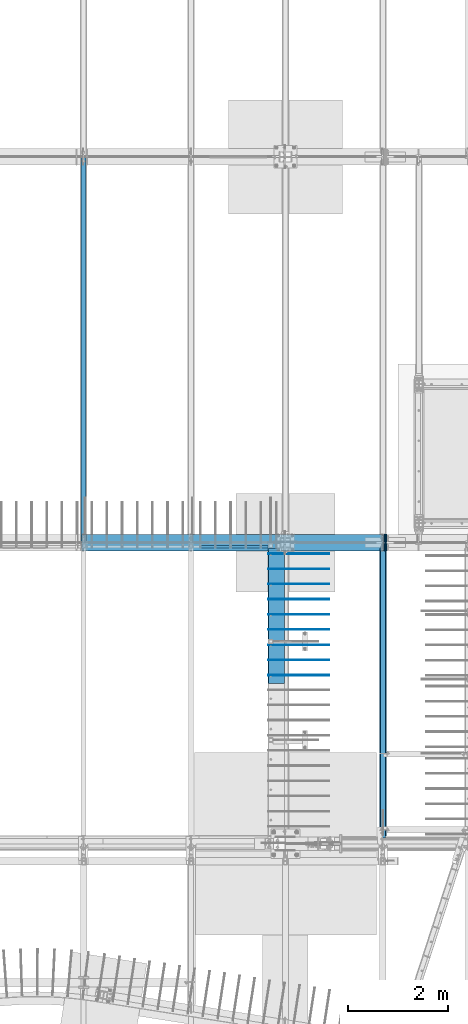
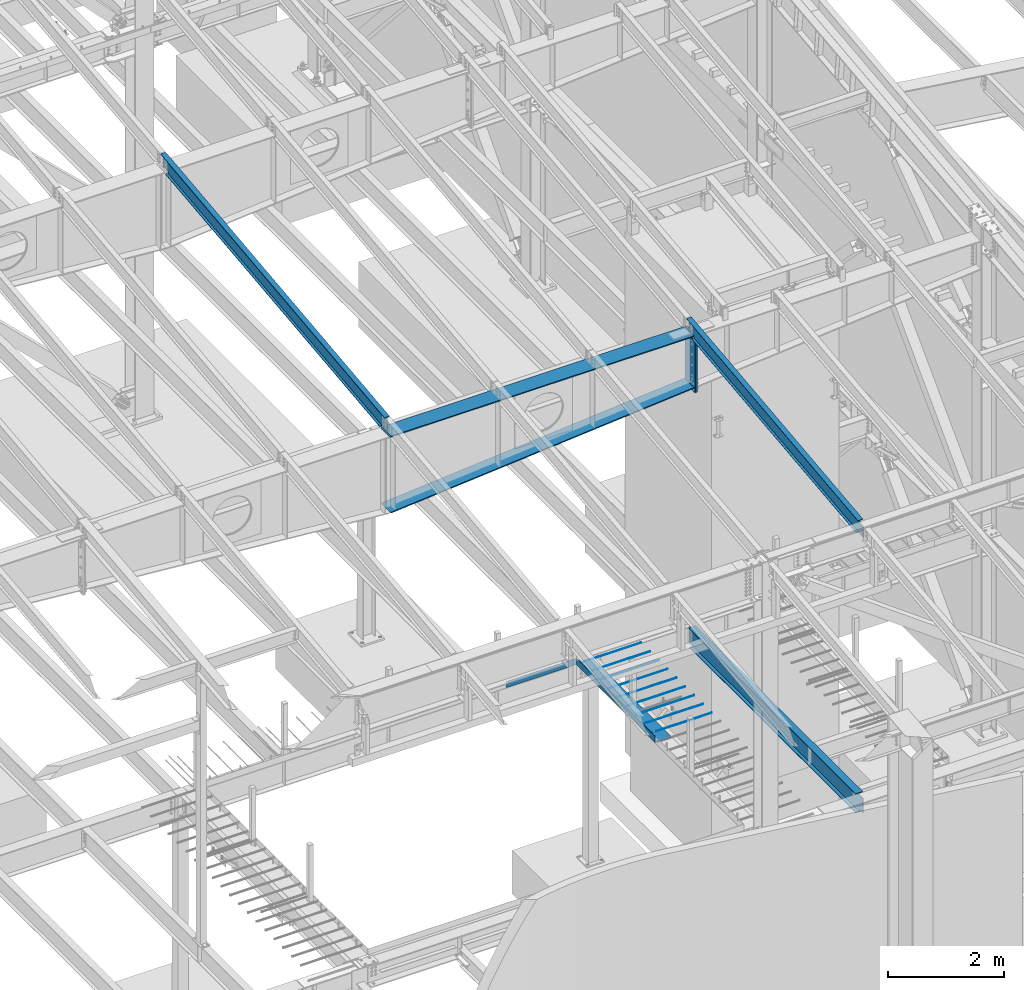
# One storey, part 718 of 1179: 18 beams, 16 elements without a shape of their own.
"""IFC2X3 building model written with IfcOpenShell, lengths in millimetres."""

from ifc_helpers import new_model, si_unit, frame, origin_with_axes, place, context, subcontext, project, spatial, faceted_brep, material, type_object, element, aggregate, save


model = new_model("IFC2X3")

# Units and contexts
model_context = context("Model", 3, precision=1e-05, world=origin_with_axes())
body_context = subcontext(model_context, "Body", "Model", "MODEL_VIEW")
ifc_project = project(units=[si_unit("LENGTHUNIT", "METRE", prefix="MILLI"), si_unit("AREAUNIT", "SQUARE_METRE"), si_unit("VOLUMEUNIT", "CUBIC_METRE"), si_unit("MASSUNIT", "GRAM", prefix="KILO"), si_unit("TIMEUNIT", "SECOND"), si_unit("PLANEANGLEUNIT", "RADIAN"), si_unit("SOLIDANGLEUNIT", "STERADIAN"), si_unit("THERMODYNAMICTEMPERATUREUNIT", "DEGREE_CELSIUS"), si_unit("LUMINOUSINTENSITYUNIT", "LUMEN")], contexts=[model_context])

# Site, building, storey
site_placement = place(None, origin_with_axes())
site = spatial("IfcSite", under=ifc_project, at=site_placement, CompositionType="ELEMENT")
building_placement = place(site_placement, origin_with_axes())
building = spatial("IfcBuilding", under=site, at=building_placement, Name="Undefined", CompositionType="ELEMENT")
storey_placement = place(building_placement, origin_with_axes())
storey = spatial("IfcBuildingStorey", under=building, at=storey_placement, Name="Undefined", CompositionType="ELEMENT", Elevation=0.0)

# Assembly, beam
assembly_1_placement = place(storey_placement, origin_with_axes())
assembly_1 = element("IfcElementAssembly", 1, at=assembly_1_placement, inside=storey, Name="BEAM", AssemblyPlace="NOTDEFINED", PredefinedType="RIGID_FRAME")
ifc_material_1 = material(Name="STEEL/A36")
beam_type_1 = type_object("IfcBeamType", PredefinedType="NOTDEFINED")
beam_1_placement = place(assembly_1_placement, frame((15417.8, 11372.85, 4235.45000610352), z_axis=(1.0, 0.0, 0.0), x_axis=(0.0, 0.0, -1.0)))
beam_1 = element("IfcBeam", 2, at=beam_1_placement, type_object=beam_type_1, material=ifc_material_1, Name="BENT_PLATE", context=body_context, shape_type="Brep", body=[
    faceted_brep([(0.0, -3.17499999999927, -695.325000000001), (0.0, -3.17499999999927, 695.325000000001), (0.0, 3.17499999999927, 695.325000000001), (0.0, 3.17499999999927, -695.325000000001), (127.000006103516, 3.17499999999927, 695.325000000001), (127.000006103516, 3.17499999999927, -695.325000000001), (133.350006103517, -3.17499999999927, -695.325000000001), (133.350006103517, -3.17499999999927, 695.325000000001), (127.000006103516, 47.6249992370613, 695.325000000001), (127.000006103516, 47.6249992370613, -695.325000000001), (133.350006103517, 47.6249992370613, 695.325000000001), (133.350006103517, 47.6249992370613, -695.325000000001)], [[[0, 1, 2, 3]], [[3, 2, 4, 5]], [[1, 0, 6, 7]], [[5, 4, 8, 9]], [[4, 2, 1, 7, 10, 8]], [[7, 6, 11, 10]], [[6, 0, 3, 5, 9, 11]], [[10, 11, 9, 8]]]),
])
aggregate(assembly_1, [beam_1])

assembly_2_placement = place(storey_placement, origin_with_axes())
assembly_2 = element("IfcElementAssembly", 3, at=assembly_2_placement, inside=storey, Name="BEAM", AssemblyPlace="NOTDEFINED", PredefinedType="RIGID_FRAME")
ifc_material_2 = material(Name="STEEL/A992")
beam_type_2 = type_object("IfcBeamType", Name="W12X14", PredefinedType="NOTDEFINED")
beam_2_placement = place(assembly_2_placement, frame((18415.0, 5452.5431792468, 9711.23798851528), z_axis=(0.0, -0.112284087038017, 0.993676146336441), x_axis=(0.0, 0.993676146336441, 0.112284087038017)))
beam_2 = element("IfcBeam", 4, at=beam_2_placement, type_object=beam_type_2, material=ifc_material_2, Name="BEAM", ObjectType="W12X14", context=body_context, shape_type="Brep", body=[
    faceted_brep([(5864.98462069385, -2.38124999999854, -144.462500002914), (5864.98462069385, -50.7999999999993, -144.462500002914), (5864.26707911321, -50.7999999999993, -150.81250000291), (5864.26707911321, 50.7999999999993, -150.81250000291), (5864.98462069385, 50.7999999999993, -144.462500002914), (5864.98462069385, 2.38124775322285, -144.462500002966), (5869.31461683509, 2.38122799874691, -106.143500465436), (5869.31461683509, -2.38124999999854, -106.143500465436), (5870.82094289051, 2.38122860688964, -101.422703766229), (5870.82094289051, -2.38124999999854, -101.422703766229), (5874.01917738662, 2.38122909448066, -97.6377023437199), (5874.01917738662, -2.38124999999854, -97.6377023437199), (5878.42241811355, 2.38122938729066, -95.3647283532646), (5878.42241811355, -2.38124999999854, -95.3647283532646), (5883.36031158621, 2.38122944073984, -94.9498214802825), (5883.36031158621, -2.38124999999854, -94.9498214802825), (6047.40696717054, -2.38124999999854, -113.486876031204), (6047.40696720504, 2.38124999999854, -113.486876035102), (6076.55490468175, -50.7999999999993, 144.462499996846), (6077.27244626239, -50.7999999999993, 150.812499996842), (114.228614327105, -50.7999999999993, 150.812499999873), (113.511072746461, -50.7999999999993, 144.462499999876), (6077.27244626239, 50.7999999999993, 150.812499996842), (114.228614327105, 50.7999999999993, 150.812499999873), (6076.55490468175, 50.7999999999993, 144.462499996846), (113.511072746461, 50.7999999999993, 144.462499999876), (6076.55490468175, 2.38124999999854, 144.462499996846), (113.511072746461, 2.38124999999854, 144.462499999876), (136.689207968453, 50.7999999999993, -144.462500000005), (136.689207968449, 50.7999999999993, -150.8125), (136.689200027815, 2.38132415300061, -150.812500000002), (136.689200027785, 2.38117582134146, -144.462500001737), (-15.7107912112788, 2.38134914656257, -150.812499999922), (-14.9932496306401, 2.38124999999854, -144.462499999927), (136.689191329944, -50.7999999999993, -144.462500000003), (136.689199270568, -2.38124999999854, -144.462500000005), (136.689199270599, -2.38117588245223, -150.8125), (136.689191329941, -50.7999999999993, -150.8125), (-14.9932496306401, -2.38124999999854, -144.462499999927), (-15.7107912112788, -2.38115088886843, -150.812499999922), (-14.7278431263294, -2.38124999999854, -142.113742314172), (10.9745586429563, -2.38124999999854, 85.3438094690136), (10.9745586429563, 2.38124999999854, 85.3438094690136), (-14.7278305511045, 2.38124999999854, -142.113631027696), (93.0025247126168, -2.38124999999854, 76.0747580626012), (93.0025247126168, 2.38124999999854, 76.0747580626012), (97.9404181857699, -2.38124999999854, 76.4896649350048), (97.9404181857699, 2.38124999999854, 76.4896649350048), (102.343658913291, -2.38124999999854, 78.7626389252728), (102.343658913291, 2.38124999999854, 78.7626389252728), (105.541893409889, -2.38124999999854, 82.5476403479479), (105.541893409889, 2.38124999999854, 82.5476403479479), (107.048219465527, -2.38124999999854, 87.2684370475545), (107.048219465527, 2.38124999999854, 87.2684370475545), (113.511072746461, -2.38124999999854, 144.462499999876), (6076.55490468175, -2.38124999999854, 144.462499996846)], [[[0, 1, 2, 3, 4, 5, 6, 7]], [[7, 6, 8, 9]], [[9, 8, 10, 11]], [[11, 10, 12, 13]], [[13, 12, 14, 15]], [[16, 15, 14, 17]], [[18, 19, 20, 21]], [[19, 22, 23, 20]], [[22, 24, 25, 23]], [[24, 26, 27, 25]], [[28, 29, 30, 31]], [[31, 30, 32, 33]], [[34, 35, 36, 37]], [[38, 39, 36, 35]], [[40, 41, 42, 43, 33, 32, 39, 38]], [[44, 45, 42, 41]], [[46, 47, 45, 44]], [[48, 49, 47, 46]], [[50, 51, 49, 48]], [[52, 53, 51, 50]], [[20, 23, 25, 27, 53, 52, 54, 21]], [[55, 18, 21, 54]], [[26, 24, 22, 19, 18, 55, 16, 17]], [[12, 10, 8, 6, 5, 31, 33, 43, 42, 45, 47, 49, 51, 53, 27, 26, 17, 14]], [[28, 31, 5, 4]], [[29, 28, 4, 3]], [[37, 36, 39, 32, 30, 29, 3, 2]], [[34, 37, 2, 1]], [[35, 34, 1, 0]], [[55, 54, 52, 50, 48, 46, 44, 41, 40, 38, 35, 0, 7, 9, 11, 13, 15, 16]]]),
])
aggregate(assembly_2, [beam_2])

assembly_3_placement = place(storey_placement, origin_with_axes())
assembly_3 = element("IfcElementAssembly", 5, at=assembly_3_placement, inside=storey, Name="BEAM", AssemblyPlace="NOTDEFINED", PredefinedType="RIGID_FRAME")
beam_type_3 = type_object("IfcBeamType", Name="W16X31", PredefinedType="NOTDEFINED")
beam_3_placement = place(assembly_3_placement, frame((18415.0, 5435.6, 3900.4875), z_axis=(0.0, 0.0, 1.0), x_axis=(0.0, 1.0, 0.0)))
beam_3 = element("IfcBeam", 6, at=beam_3_placement, type_object=beam_type_3, material=ifc_material_2, Name="BEAM", ObjectType="W16X31", context=body_context, shape_type="Brep", body=[
    faceted_brep([(19.84375, -3.17499999999927, -141.2875), (19.84375, 3.17499999999927, -141.2875), (142.081250190735, 3.17517002077875, -141.2875), (142.081250190735, -3.17499999999927, -141.2875), (146.94132970878, 3.17517064521599, -142.254229922588), (146.94132970878, -3.17499999999927, -142.254229922588), (151.061506176934, 3.17517242088434, -145.007243823066), (151.061506176934, -3.17499999999927, -145.007243823066), (153.814520077412, 3.17517507744924, -149.12742029122), (153.814520077412, -3.17499999999927, -149.12742029122), (154.78125, -3.17499999999927, -153.987499809266), (154.78125, 3.17517821047295, -153.987499809266), (154.780750000001, 3.17549991607666, -190.5), (154.780750000001, 3.17549991607666, -201.6125), (154.78125, -69.8499999999985, -201.6125), (154.78125, -69.8499999999985, -190.5), (154.78125, -3.17499999999927, -190.5), (5900.73750167641, 69.8499999985015, -190.5), (5900.73750167641, 69.8499999985015, -201.6125), (154.780750000001, 69.8499999999985, -201.6125), (154.780750000001, 69.8499999999985, -190.5), (5900.73750007622, 3.17499999850133, -190.5), (5900.73749999986, 3.17549991607666, -201.6125), (6027.73750007621, 3.17499999846859, -190.5), (6027.7375, 3.17549991607666, -201.6125), (5927.72500167648, 69.8499999984942, 190.5), (5927.72500167647, 3.17499999849406, 190.5), (154.78125, 3.17499999999927, 190.5), (154.78125, 69.8499999999985, 190.5), (142.081250190735, -3.17499999999927, 163.5125), (142.081250190735, 3.17497498411103, 163.5125), (19.84375, 3.17499999999927, 163.5125), (19.84375, -3.17499999999927, 163.5125), (146.94132970878, -3.17499999999927, 164.479229922588), (146.94132970878, 3.17497436273698, 164.479229922588), (151.061506176934, -3.17499999999927, 167.232243823066), (151.061506176934, 3.17497259321317, 167.232243823066), (153.814520077412, -3.17499999999927, 171.352420291219), (153.814520077412, 3.17496994493558, 171.352420291219), (154.78125, -3.17499999999927, 176.212499809265), (154.78125, 3.17496682107958, 176.212499809265), (5927.72500167645, -69.8500000015056, 201.6125), (5927.72500167648, 69.8499999984942, 201.6125), (154.78125, 69.8499999999985, 201.6125), (154.78125, -69.8499999999985, 201.6125), (5927.72500167645, -69.8500000015056, 190.5), (154.78125, -69.8499999999985, 190.5), (5927.72500167647, -3.1750000015054, 190.5), (154.78125, -3.17499999999927, 190.5), (5927.72500167647, -3.1750000015054, 182.562499809265), (5927.72500167647, 3.17499999849406, 182.562499809265), (5928.69173159905, -3.1750000015054, 177.702420291219), (5928.69173159905, 3.17499999849406, 177.702420291219), (5931.44474549953, -3.17500000150721, 173.582243823066), (5931.44474549953, 3.17499999849315, 173.582243823066), (5935.56492196769, -3.17500000150812, 170.829229922588), (5935.56492196769, 3.17499999849224, 170.829229922588), (5940.42500148573, -3.17500000150903, 169.8625), (5940.42500148573, 3.17499999849133, 169.8625), (6027.73749992381, -3.17500000153177, 169.8625), (6027.73750007621, 3.17499999846859, 169.8625), (6027.73749992381, -3.17500000153177, -190.5), (6027.73749832361, -69.850000001531, -190.5), (6027.73749832361, -69.850000001531, -201.6125)], [[[0, 1, 2, 3]], [[3, 2, 4, 5]], [[5, 4, 6, 7]], [[7, 6, 8, 9]], [[10, 11, 12, 13, 14, 15, 16]], [[9, 8, 11, 10]], [[17, 18, 19, 20]], [[21, 22, 18, 17]], [[23, 24, 22, 21]], [[25, 26, 27, 28]], [[29, 30, 31, 32]], [[33, 34, 30, 29]], [[35, 36, 34, 33]], [[37, 38, 36, 35]], [[39, 40, 38, 37]], [[41, 42, 43, 44]], [[45, 41, 44, 46]], [[47, 45, 46, 48]], [[44, 43, 28, 27, 40, 39, 48, 46]], [[42, 25, 28, 43]], [[41, 45, 47, 49, 50, 26, 25, 42]], [[51, 52, 50, 49]], [[53, 54, 52, 51]], [[55, 56, 54, 53]], [[57, 58, 56, 55]], [[59, 60, 58, 57]], [[61, 62, 63, 24, 23, 60, 59]], [[62, 61, 16, 15]], [[63, 62, 15, 14]], [[19, 18, 22, 24, 63, 14, 13]], [[20, 19, 13, 12]], [[21, 17, 20, 12]], [[6, 4, 2, 1, 31, 30, 34, 36, 38, 40, 27, 26, 50, 52, 54, 56, 58, 60, 23, 21, 12, 11, 8]], [[32, 31, 1, 0]], [[61, 59, 57, 55, 53, 51, 49, 47, 48, 39, 37, 35, 33, 29, 32, 0, 3, 5, 7, 9, 10, 16]]]),
])
aggregate(assembly_3, [beam_3])

assembly_4_placement = place(storey_placement, origin_with_axes())
assembly_4 = element("IfcElementAssembly", 7, at=assembly_4_placement, inside=storey, Name="RAFTER BEAM", AssemblyPlace="NOTDEFINED", PredefinedType="RIGID_FRAME")
beam_type_4 = type_object("IfcBeamType", PredefinedType="NOTDEFINED")
beam_4_placement = place(assembly_4_placement, frame((18453.1, 11645.9093353614, 9647.25885710149), z_axis=(0.0, 0.0, 1.0), x_axis=(0.0, -1.0, 0.0)))
beam_4 = element("IfcBeam", 8, at=beam_4_placement, type_object=beam_type_4, material=ifc_material_1, Name="PLATE", context=body_context, shape_type="Brep", body=[
    faceted_brep([(0.0, 12.7000000000007, -604.8375), (0.0, 12.7000000000007, 604.8375), (330.199999998662, 12.7000000000007, 604.8375), (330.199999998662, 12.7000000000007, -604.8375), (0.0, -12.7000000000007, 604.8375), (330.199999998662, -12.7000000000007, 604.8375), (0.0, -12.7000000000007, -604.8375), (330.199999998662, -12.7000000000007, -604.8375)], [[[0, 1, 2, 3]], [[1, 4, 5, 2]], [[4, 6, 7, 5]], [[6, 0, 3, 7]], [[5, 7, 3, 2]], [[6, 4, 1, 0]]]),
])

assembly_5_placement = place(storey_placement, origin_with_axes())
assembly_5 = element("IfcElementAssembly", 9, at=assembly_5_placement, inside=storey, Name="RAFTER BEAM", AssemblyPlace="NOTDEFINED", PredefinedType="RIGID_FRAME")
beam_5_placement = place(assembly_5_placement, frame((18478.5, 11645.9093353614, 9647.25885710149), z_axis=(0.0, 0.0, 1.0), x_axis=(0.0, -1.0, 0.0)))
beam_5 = element("IfcBeam", 10, at=beam_5_placement, type_object=beam_type_4, material=ifc_material_1, Name="PLATE", context=body_context, shape_type="Brep", body=[
    faceted_brep([(0.0, 12.7000000000007, -604.8375), (0.0, 12.7000000000007, 604.8375), (330.199999998662, 12.7000000000007, 604.8375), (330.199999998662, 12.7000000000007, -604.8375), (0.0, -12.7000000000007, 604.8375), (330.199999998662, -12.7000000000007, 604.8375), (0.0, -12.7000000000007, -604.8375), (330.199999998662, -12.7000000000007, -604.8375)], [[[0, 1, 2, 3]], [[1, 4, 5, 2]], [[4, 6, 7, 5]], [[6, 0, 3, 7]], [[5, 7, 3, 2]], [[6, 4, 1, 0]]]),
])
aggregate(assembly_5, [beam_5])

# Beam
beam_type_5 = type_object("IfcBeamType", PredefinedType="NOTDEFINED")
beam_6_placement = place(assembly_4_placement, frame((12370.7428862919, 11480.8093353585, 8637.648930532), z_axis=(0.0, 1.0, 0.0), x_axis=(0.996393807714311, 0.0, 0.0848491599756719)))
beam_6 = element("IfcBeam", 11, at=beam_6_placement, type_object=beam_type_5, material=ifc_material_1, Name="PLATE", context=body_context, shape_type="Brep", body=[
    faceted_brep([(6090.71942911093, 11.0885263453838, 165.1), (6072.00277546247, -11.112499998424, 165.1), (6072.00277546247, -11.112499998424, -165.1), (6090.6783848247, 11.1125000015836, -165.1), (18.7420566108085, 11.1124996782601, 165.1), (18.7420566108103, 11.1125000000056, -165.1), (1.66062363859965e-09, -11.1125000000084, -165.1), (1.66062363859965e-09, -11.1125000000084, 165.1)], [[[0, 1, 2, 3]], [[4, 5, 6, 7]], [[5, 4, 0, 3]], [[6, 5, 3, 2]], [[7, 6, 2, 1]], [[4, 7, 1, 0]]]),
])

beam_7_placement = place(assembly_4_placement, frame((12369.8, 11480.8093353614, 10240.98385672), z_axis=(0.0, -1.0, 0.0), x_axis=(1.0, 0.0, 0.0)))
beam_7 = element("IfcBeam", 12, at=beam_7_placement, type_object=beam_type_5, material=ifc_material_1, Name="PLATE", context=body_context, shape_type="Brep", body=[
    faceted_brep([(6070.6, -11.1124999999993, 165.1), (6070.6, -11.1124999999993, -165.1), (6048.37499961853, 11.1124999999993, -165.1), (6048.37499961853, 11.1125000014017, 165.1), (22.2250003814697, 11.1125003814705, 165.1), (22.2250003814697, 11.1124999999993, -165.1), (1.66062363859965e-09, -11.1125000000084, -165.1), (1.66062363859965e-09, -11.1125000000084, 165.1)], [[[0, 1, 2, 3]], [[4, 5, 6, 7]], [[4, 7, 0, 3]], [[5, 4, 3, 2]], [[6, 5, 2, 1]], [[7, 6, 1, 0]]]),
])

aggregate(assembly_4, [beam_4, beam_6, beam_7])

# Assembly, beam
assembly_6_placement = place(storey_placement, origin_with_axes())
assembly_6 = element("IfcElementAssembly", 13, at=assembly_6_placement, inside=storey, Name="#4 DOWEL", AssemblyPlace="NOTDEFINED", PredefinedType="NOTDEFINED")
ifc_material_3 = material(Name="REBAR/A615-40")
beam_type_6 = type_object("IfcBeamType", Name="#4 DOWEL", PredefinedType="NOTDEFINED")
beam_8_placement = place(assembly_6_placement, frame((16119.475, 11258.55, 4203.70000610352), z_axis=(0.0, 0.0, 1.0), x_axis=(1.0, 0.0, 0.0)))
beam_8 = element("IfcBeam", 14, at=beam_8_placement, type_object=beam_type_6, material=ifc_material_3, Name="#4 DOWEL", ObjectType="#4 DOWEL", context=body_context, shape_type="Brep", body=[
    faceted_brep([(0.0, -6.34999999999854, 0.0), (0.0, -4.49012806053361, -4.49012806053452), (1219.2, -4.49012806053543, -4.49012806053452), (1219.2, -6.35000000000036, 0.0), (0.0, 0.0, -6.34999999999991), (1219.2, 0.0, -6.35000000000036), (0.0, 4.49012806053361, -4.49012806053452), (1219.2, 4.49012806053543, -4.49012806053452), (0.0, 6.34999999999854, 0.0), (1219.2, 6.35000000000036, 0.0), (0.0, 4.49012806053361, 4.49012806053452), (1219.2, 4.49012806053543, 4.49012806053452), (0.0, 0.0, 6.34999999999991), (1219.2, 0.0, 6.35000000000036), (0.0, -4.49012806053361, 4.49012806053452), (1219.2, -4.49012806053543, 4.49012806053452)], [[[0, 1, 2, 3]], [[1, 4, 5, 2]], [[4, 6, 7, 5]], [[6, 8, 9, 7]], [[8, 10, 11, 9]], [[10, 12, 13, 11]], [[12, 14, 15, 13]], [[14, 0, 3, 15]], [[5, 7, 9, 11, 13, 15, 3, 2]], [[14, 12, 10, 8, 6, 4, 1, 0]]]),
])
aggregate(assembly_6, [beam_8])

assembly_7_placement = place(storey_placement, origin_with_axes())
assembly_7 = element("IfcElementAssembly", 15, at=assembly_7_placement, inside=storey, Name="#4 DOWEL", AssemblyPlace="NOTDEFINED", PredefinedType="NOTDEFINED")
beam_9_placement = place(assembly_7_placement, frame((16119.475, 10953.75, 4203.70000610352), z_axis=(0.0, 0.0, 1.0), x_axis=(1.0, 0.0, 0.0)))
beam_9 = element("IfcBeam", 16, at=beam_9_placement, type_object=beam_type_6, material=ifc_material_3, Name="#4 DOWEL", ObjectType="#4 DOWEL", context=body_context, shape_type="Brep", body=[
    faceted_brep([(0.0, -6.34999999999854, 0.0), (0.0, -4.49012806053361, -4.49012806053452), (1219.2, -4.49012806053543, -4.49012806053452), (1219.2, -6.35000000000036, 0.0), (0.0, 0.0, -6.34999999999991), (1219.2, 0.0, -6.35000000000036), (0.0, 4.49012806053361, -4.49012806053452), (1219.2, 4.49012806053543, -4.49012806053452), (0.0, 6.34999999999854, 0.0), (1219.2, 6.35000000000036, 0.0), (0.0, 4.49012806053361, 4.49012806053452), (1219.2, 4.49012806053543, 4.49012806053452), (0.0, 0.0, 6.34999999999991), (1219.2, 0.0, 6.35000000000036), (0.0, -4.49012806053361, 4.49012806053452), (1219.2, -4.49012806053543, 4.49012806053452)], [[[0, 1, 2, 3]], [[1, 4, 5, 2]], [[4, 6, 7, 5]], [[6, 8, 9, 7]], [[8, 10, 11, 9]], [[10, 12, 13, 11]], [[12, 14, 15, 13]], [[14, 0, 3, 15]], [[5, 7, 9, 11, 13, 15, 3, 2]], [[14, 12, 10, 8, 6, 4, 1, 0]]]),
])
aggregate(assembly_7, [beam_9])

assembly_8_placement = place(storey_placement, origin_with_axes())
assembly_8 = element("IfcElementAssembly", 17, at=assembly_8_placement, inside=storey, Name="#4 DOWEL", AssemblyPlace="NOTDEFINED", PredefinedType="NOTDEFINED")
beam_10_placement = place(assembly_8_placement, frame((16119.475, 10648.95, 4203.70000610352), z_axis=(0.0, 0.0, 1.0), x_axis=(1.0, 0.0, 0.0)))
beam_10 = element("IfcBeam", 18, at=beam_10_placement, type_object=beam_type_6, material=ifc_material_3, Name="#4 DOWEL", ObjectType="#4 DOWEL", context=body_context, shape_type="Brep", body=[
    faceted_brep([(0.0, -6.34999999999854, 0.0), (0.0, -4.49012806053361, -4.49012806053452), (1219.2, -4.49012806053543, -4.49012806053452), (1219.2, -6.35000000000036, 0.0), (0.0, 0.0, -6.34999999999991), (1219.2, 0.0, -6.35000000000036), (0.0, 4.49012806053361, -4.49012806053452), (1219.2, 4.49012806053543, -4.49012806053452), (0.0, 6.34999999999854, 0.0), (1219.2, 6.35000000000036, 0.0), (0.0, 4.49012806053361, 4.49012806053452), (1219.2, 4.49012806053543, 4.49012806053452), (0.0, 0.0, 6.34999999999991), (1219.2, 0.0, 6.35000000000036), (0.0, -4.49012806053361, 4.49012806053452), (1219.2, -4.49012806053543, 4.49012806053452)], [[[0, 1, 2, 3]], [[1, 4, 5, 2]], [[4, 6, 7, 5]], [[6, 8, 9, 7]], [[8, 10, 11, 9]], [[10, 12, 13, 11]], [[12, 14, 15, 13]], [[14, 0, 3, 15]], [[5, 7, 9, 11, 13, 15, 3, 2]], [[14, 12, 10, 8, 6, 4, 1, 0]]]),
])
aggregate(assembly_8, [beam_10])

assembly_9_placement = place(storey_placement, origin_with_axes())
assembly_9 = element("IfcElementAssembly", 19, at=assembly_9_placement, inside=storey, Name="#4 DOWEL", AssemblyPlace="NOTDEFINED", PredefinedType="NOTDEFINED")
beam_11_placement = place(assembly_9_placement, frame((16119.475, 10344.15, 4203.70000610352), z_axis=(0.0, 0.0, 1.0), x_axis=(1.0, 0.0, 0.0)))
beam_11 = element("IfcBeam", 20, at=beam_11_placement, type_object=beam_type_6, material=ifc_material_3, Name="#4 DOWEL", ObjectType="#4 DOWEL", context=body_context, shape_type="Brep", body=[
    faceted_brep([(0.0, -6.34999999999854, 0.0), (0.0, -4.49012806053361, -4.49012806053452), (1219.2, -4.49012806053543, -4.49012806053452), (1219.2, -6.35000000000036, 0.0), (0.0, 0.0, -6.34999999999991), (1219.2, 0.0, -6.35000000000036), (0.0, 4.49012806053361, -4.49012806053452), (1219.2, 4.49012806053543, -4.49012806053452), (0.0, 6.34999999999854, 0.0), (1219.2, 6.35000000000036, 0.0), (0.0, 4.49012806053361, 4.49012806053452), (1219.2, 4.49012806053543, 4.49012806053452), (0.0, 0.0, 6.34999999999991), (1219.2, 0.0, 6.35000000000036), (0.0, -4.49012806053361, 4.49012806053452), (1219.2, -4.49012806053543, 4.49012806053452)], [[[0, 1, 2, 3]], [[1, 4, 5, 2]], [[4, 6, 7, 5]], [[6, 8, 9, 7]], [[8, 10, 11, 9]], [[10, 12, 13, 11]], [[12, 14, 15, 13]], [[14, 0, 3, 15]], [[5, 7, 9, 11, 13, 15, 3, 2]], [[14, 12, 10, 8, 6, 4, 1, 0]]]),
])
aggregate(assembly_9, [beam_11])

assembly_10_placement = place(storey_placement, origin_with_axes())
assembly_10 = element("IfcElementAssembly", 21, at=assembly_10_placement, inside=storey, Name="#4 DOWEL", AssemblyPlace="NOTDEFINED", PredefinedType="NOTDEFINED")
beam_12_placement = place(assembly_10_placement, frame((16119.475, 10039.35, 4203.70000610352), z_axis=(0.0, 0.0, 1.0), x_axis=(1.0, 0.0, 0.0)))
beam_12 = element("IfcBeam", 22, at=beam_12_placement, type_object=beam_type_6, material=ifc_material_3, Name="#4 DOWEL", ObjectType="#4 DOWEL", context=body_context, shape_type="Brep", body=[
    faceted_brep([(0.0, -6.34999999999854, 0.0), (0.0, -4.49012806053361, -4.49012806053452), (1219.2, -4.49012806053543, -4.49012806053452), (1219.2, -6.35000000000036, 0.0), (0.0, 0.0, -6.34999999999991), (1219.2, 0.0, -6.35000000000036), (0.0, 4.49012806053361, -4.49012806053452), (1219.2, 4.49012806053543, -4.49012806053452), (0.0, 6.34999999999854, 0.0), (1219.2, 6.35000000000036, 0.0), (0.0, 4.49012806053361, 4.49012806053452), (1219.2, 4.49012806053543, 4.49012806053452), (0.0, 0.0, 6.34999999999991), (1219.2, 0.0, 6.35000000000036), (0.0, -4.49012806053361, 4.49012806053452), (1219.2, -4.49012806053543, 4.49012806053452)], [[[0, 1, 2, 3]], [[1, 4, 5, 2]], [[4, 6, 7, 5]], [[6, 8, 9, 7]], [[8, 10, 11, 9]], [[10, 12, 13, 11]], [[12, 14, 15, 13]], [[14, 0, 3, 15]], [[5, 7, 9, 11, 13, 15, 3, 2]], [[14, 12, 10, 8, 6, 4, 1, 0]]]),
])
aggregate(assembly_10, [beam_12])

assembly_11_placement = place(storey_placement, origin_with_axes())
assembly_11 = element("IfcElementAssembly", 23, at=assembly_11_placement, inside=storey, Name="#4 DOWEL", AssemblyPlace="NOTDEFINED", PredefinedType="NOTDEFINED")
beam_13_placement = place(assembly_11_placement, frame((16119.475, 9734.55, 4203.70000610352), z_axis=(0.0, 0.0, 1.0), x_axis=(1.0, 0.0, 0.0)))
beam_13 = element("IfcBeam", 24, at=beam_13_placement, type_object=beam_type_6, material=ifc_material_3, Name="#4 DOWEL", ObjectType="#4 DOWEL", context=body_context, shape_type="Brep", body=[
    faceted_brep([(0.0, -6.34999999999854, 0.0), (0.0, -4.49012806053361, -4.49012806053452), (1219.2, -4.49012806053543, -4.49012806053452), (1219.2, -6.35000000000036, 0.0), (0.0, 0.0, -6.34999999999991), (1219.2, 0.0, -6.35000000000036), (0.0, 4.49012806053361, -4.49012806053452), (1219.2, 4.49012806053543, -4.49012806053452), (0.0, 6.34999999999854, 0.0), (1219.2, 6.35000000000036, 0.0), (0.0, 4.49012806053361, 4.49012806053452), (1219.2, 4.49012806053543, 4.49012806053452), (0.0, 0.0, 6.34999999999991), (1219.2, 0.0, 6.35000000000036), (0.0, -4.49012806053361, 4.49012806053452), (1219.2, -4.49012806053543, 4.49012806053452)], [[[0, 1, 2, 3]], [[1, 4, 5, 2]], [[4, 6, 7, 5]], [[6, 8, 9, 7]], [[8, 10, 11, 9]], [[10, 12, 13, 11]], [[12, 14, 15, 13]], [[14, 0, 3, 15]], [[5, 7, 9, 11, 13, 15, 3, 2]], [[14, 12, 10, 8, 6, 4, 1, 0]]]),
])
aggregate(assembly_11, [beam_13])

assembly_12_placement = place(storey_placement, origin_with_axes())
assembly_12 = element("IfcElementAssembly", 25, at=assembly_12_placement, inside=storey, Name="#4 DOWEL", AssemblyPlace="NOTDEFINED", PredefinedType="NOTDEFINED")
beam_14_placement = place(assembly_12_placement, frame((16119.475, 9429.75, 4203.70000610352), z_axis=(0.0, 0.0, 1.0), x_axis=(1.0, 0.0, 0.0)))
beam_14 = element("IfcBeam", 26, at=beam_14_placement, type_object=beam_type_6, material=ifc_material_3, Name="#4 DOWEL", ObjectType="#4 DOWEL", context=body_context, shape_type="Brep", body=[
    faceted_brep([(0.0, -6.34999999999854, 0.0), (0.0, -4.49012806053361, -4.49012806053452), (1219.2, -4.49012806053543, -4.49012806053452), (1219.2, -6.35000000000036, 0.0), (0.0, 0.0, -6.34999999999991), (1219.2, 0.0, -6.35000000000036), (0.0, 4.49012806053361, -4.49012806053452), (1219.2, 4.49012806053543, -4.49012806053452), (0.0, 6.34999999999854, 0.0), (1219.2, 6.35000000000036, 0.0), (0.0, 4.49012806053361, 4.49012806053452), (1219.2, 4.49012806053543, 4.49012806053452), (0.0, 0.0, 6.34999999999991), (1219.2, 0.0, 6.35000000000036), (0.0, -4.49012806053361, 4.49012806053452), (1219.2, -4.49012806053543, 4.49012806053452)], [[[0, 1, 2, 3]], [[1, 4, 5, 2]], [[4, 6, 7, 5]], [[6, 8, 9, 7]], [[8, 10, 11, 9]], [[10, 12, 13, 11]], [[12, 14, 15, 13]], [[14, 0, 3, 15]], [[5, 7, 9, 11, 13, 15, 3, 2]], [[14, 12, 10, 8, 6, 4, 1, 0]]]),
])
aggregate(assembly_12, [beam_14])

assembly_13_placement = place(storey_placement, origin_with_axes())
assembly_13 = element("IfcElementAssembly", 27, at=assembly_13_placement, inside=storey, Name="#4 DOWEL", AssemblyPlace="NOTDEFINED", PredefinedType="NOTDEFINED")
beam_15_placement = place(assembly_13_placement, frame((16119.475, 9124.95, 4203.70000610352), z_axis=(0.0, 0.0, 1.0), x_axis=(1.0, 0.0, 0.0)))
beam_15 = element("IfcBeam", 28, at=beam_15_placement, type_object=beam_type_6, material=ifc_material_3, Name="#4 DOWEL", ObjectType="#4 DOWEL", context=body_context, shape_type="Brep", body=[
    faceted_brep([(0.0, -6.34999999999854, 0.0), (0.0, -4.49012806053361, -4.49012806053452), (1219.2, -4.49012806053543, -4.49012806053452), (1219.2, -6.35000000000036, 0.0), (0.0, 0.0, -6.34999999999991), (1219.2, 0.0, -6.35000000000036), (0.0, 4.49012806053361, -4.49012806053452), (1219.2, 4.49012806053543, -4.49012806053452), (0.0, 6.34999999999854, 0.0), (1219.2, 6.35000000000036, 0.0), (0.0, 4.49012806053361, 4.49012806053452), (1219.2, 4.49012806053543, 4.49012806053452), (0.0, 0.0, 6.34999999999991), (1219.2, 0.0, 6.35000000000036), (0.0, -4.49012806053361, 4.49012806053452), (1219.2, -4.49012806053543, 4.49012806053452)], [[[0, 1, 2, 3]], [[1, 4, 5, 2]], [[4, 6, 7, 5]], [[6, 8, 9, 7]], [[8, 10, 11, 9]], [[10, 12, 13, 11]], [[12, 14, 15, 13]], [[14, 0, 3, 15]], [[5, 7, 9, 11, 13, 15, 3, 2]], [[14, 12, 10, 8, 6, 4, 1, 0]]]),
])
aggregate(assembly_13, [beam_15])

assembly_14_placement = place(storey_placement, origin_with_axes())
assembly_14 = element("IfcElementAssembly", 29, at=assembly_14_placement, inside=storey, Name="#4 DOWEL", AssemblyPlace="NOTDEFINED", PredefinedType="NOTDEFINED")
beam_16_placement = place(assembly_14_placement, frame((16119.475, 8820.15, 4203.70000610352), z_axis=(0.0, 0.0, 1.0), x_axis=(1.0, 0.0, 0.0)))
beam_16 = element("IfcBeam", 30, at=beam_16_placement, type_object=beam_type_6, material=ifc_material_3, Name="#4 DOWEL", ObjectType="#4 DOWEL", context=body_context, shape_type="Brep", body=[
    faceted_brep([(0.0, -6.34999999999854, 0.0), (0.0, -4.49012806053361, -4.49012806053452), (1219.2, -4.49012806053543, -4.49012806053452), (1219.2, -6.35000000000036, 0.0), (0.0, 0.0, -6.34999999999991), (1219.2, 0.0, -6.35000000000036), (0.0, 4.49012806053361, -4.49012806053452), (1219.2, 4.49012806053543, -4.49012806053452), (0.0, 6.34999999999854, 0.0), (1219.2, 6.35000000000036, 0.0), (0.0, 4.49012806053361, 4.49012806053452), (1219.2, 4.49012806053543, 4.49012806053452), (0.0, 0.0, 6.34999999999991), (1219.2, 0.0, 6.35000000000036), (0.0, -4.49012806053361, 4.49012806053452), (1219.2, -4.49012806053543, 4.49012806053452)], [[[0, 1, 2, 3]], [[1, 4, 5, 2]], [[4, 6, 7, 5]], [[6, 8, 9, 7]], [[8, 10, 11, 9]], [[10, 12, 13, 11]], [[12, 14, 15, 13]], [[14, 0, 3, 15]], [[5, 7, 9, 11, 13, 15, 3, 2]], [[14, 12, 10, 8, 6, 4, 1, 0]]]),
])
aggregate(assembly_14, [beam_16])

assembly_15_placement = place(storey_placement, origin_with_axes())
assembly_15 = element("IfcElementAssembly", 31, at=assembly_15_placement, inside=storey, Name="BEAM", AssemblyPlace="NOTDEFINED", PredefinedType="RIGID_FRAME")
beam_type_7 = type_object("IfcBeamType", PredefinedType="NOTDEFINED")
beam_17_placement = place(assembly_15_placement, frame((16443.325012207, 10010.775, 4105.27500000003), z_axis=(0.0, -1.0, 0.0), x_axis=(-1.0, 0.0, 0.0)))
beam_17 = element("IfcBeam", 32, at=beam_17_placement, type_object=beam_type_7, material=ifc_material_1, Name="BENT_PLATE", context=body_context, shape_type="Brep", body=[
    faceted_brep([(0.0, -3.17500000000018, -1357.3125), (0.0, -3.17500000000018, 1357.3125), (0.0, 3.17500000000018, 1357.3125), (0.0, 3.17500000000018, -1357.3125), (330.200012207031, 3.17500000000018, 1357.3125), (330.200012207031, 3.17500000000018, -1357.3125), (323.850012207033, -3.17500000000018, -1357.3125), (323.850012207033, -3.17500000000018, 1357.3125), (330.200012207031, -130.175006103515, 1357.3125), (330.200012207031, -130.175006103515, -1357.3125), (323.850012207033, -130.175006103515, 1357.3125), (323.850012207033, -130.175006103515, -1357.3125)], [[[0, 1, 2, 3]], [[3, 2, 4, 5]], [[1, 0, 6, 7]], [[5, 4, 8, 9]], [[4, 2, 1, 7, 10, 8]], [[7, 6, 11, 10]], [[6, 0, 3, 5, 9, 11]], [[10, 11, 9, 8]]]),
])
aggregate(assembly_15, [beam_17])

assembly_16_placement = place(storey_placement, origin_with_axes())
assembly_16 = element("IfcElementAssembly", 33, at=assembly_16_placement, inside=storey, Name="BEAM", AssemblyPlace="NOTDEFINED", PredefinedType="RIGID_FRAME")
beam_type_8 = type_object("IfcBeamType", Name="W12X22", PredefinedType="NOTDEFINED")
beam_18_placement = place(assembly_16_placement, frame((12407.9, 11498.2779321842, 10389.6051906331), z_axis=(0.0, -0.112284087038017, 0.993676146336441), x_axis=(0.0, 0.993676146336441, 0.112284087038017)))
beam_18 = element("IfcBeam", 34, at=beam_18_placement, type_object=beam_type_8, material=ifc_material_2, Name="BEAM", ObjectType="W12X22", context=body_context, shape_type="Brep", body=[
    faceted_brep([(7583.46730043383, -3.17499999999927, -144.462500002994), (7583.46730043383, -50.7999999999993, -144.462500002994), (7582.21160266769, -50.7999999999993, -155.575000002988), (7582.21160266769, 50.7999999999993, -155.575000002988), (7583.46730043383, 50.7999999999993, -144.462500002994), (7583.46730043383, 3.17499999999927, -144.462500002994), (7586.83832669432, 3.17499999999927, -114.630059163946), (7586.83832669432, -3.17499999999927, -114.630059163946), (7588.34465274973, 3.17499999999927, -109.909262464753), (7588.34465274973, -3.17499999999927, -109.909262464753), (7591.54288724583, 3.17499999999927, -106.124261042249), (7591.54288724583, -3.17499999999927, -106.124261042249), (7595.94612797272, 3.17499999999927, -103.851287051781), (7595.94612797272, -3.17499999999927, -103.851287051781), (7600.88402144536, 3.17499999999927, -103.436380178771), (7600.88402144536, -3.17499999999927, -103.436380178771), (7758.6208335002, -3.17499999999927, -121.260430776909), (7758.62083354224, 3.17499999999927, -121.26043078166), (6.38101702707718, -50.7999999999993, 155.574999999912), (5.12531926095107, -50.7999999999993, 144.46249999992), (7788.64717240277, -50.7999999999993, 144.462499996762), (7789.9028701689, -50.7999999999993, 155.574999996754), (6.38101702707718, 50.7999999999993, 155.574999999912), (7789.9028701689, 50.7999999999993, 155.574999996754), (5.12531926095107, 50.7999999999993, 144.46249999992), (7788.64717240277, 50.7999999999993, 144.462499996762), (5.12531926095107, 3.17499999999927, 144.46249999992), (7788.64717240277, 3.17499999999927, 144.462499996762), (145.30344487597, -3.17499999999927, -142.022226300664), (145.30344487597, 3.17499999999927, -142.022226300664), (145.027696926005, 3.17499999999927, -144.462499999976), (145.027696926005, 50.7999999999993, -144.462499999976), (143.771999161854, 50.7999999999993, -155.574999999972), (143.771999161854, -50.7999999999993, -155.574999999972), (145.027696926005, -50.7999999999993, -144.462499999976), (145.027696926005, -3.17499999999927, -144.462499999976), (-25.0716067072917, -3.17499999999927, -122.770071196437), (-25.0716067072917, 3.17499999999927, -122.770071196437), (5.12531926095107, -3.17499999999927, 144.46249999992), (7788.64717240277, -3.17499999999927, 144.462499996762)], [[[0, 1, 2, 3, 4, 5, 6, 7]], [[7, 6, 8, 9]], [[9, 8, 10, 11]], [[11, 10, 12, 13]], [[13, 12, 14, 15]], [[16, 15, 14, 17]], [[18, 19, 20, 21]], [[22, 18, 21, 23]], [[24, 22, 23, 25]], [[26, 24, 25, 27]], [[28, 29, 30, 31, 32, 33, 34, 35]], [[36, 37, 29, 28]], [[38, 19, 18, 22, 24, 26, 37, 36]], [[19, 38, 39, 20]], [[27, 25, 23, 21, 20, 39, 16, 17]], [[12, 10, 8, 6, 5, 30, 29, 37, 26, 27, 17, 14]], [[31, 30, 5, 4]], [[32, 31, 4, 3]], [[33, 32, 3, 2]], [[34, 33, 2, 1]], [[35, 34, 1, 0]], [[39, 38, 36, 28, 35, 0, 7, 9, 11, 13, 15, 16]]]),
])
aggregate(assembly_16, [beam_18])

save(model, "model.ifc")
